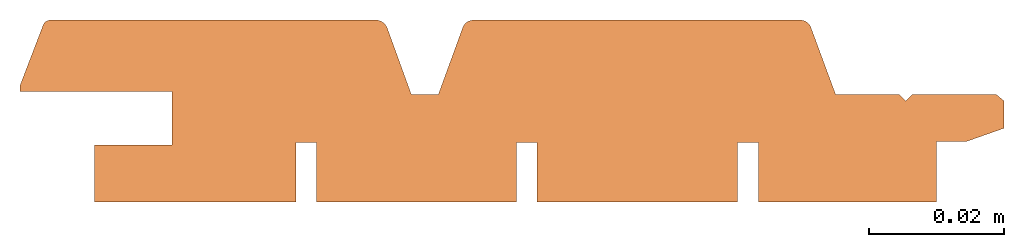
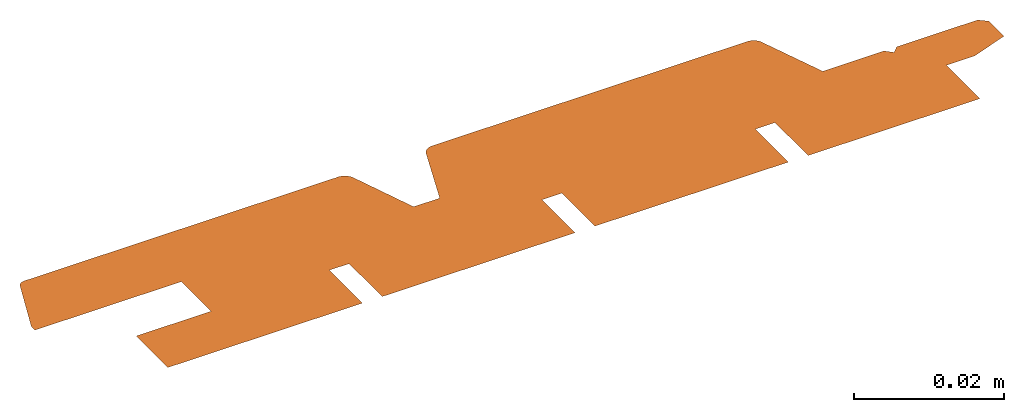
# One storey: 1 proxy.
"""IFC2X3 building model written with IfcOpenShell, lengths in millimetres."""

from ifc_helpers import new_model, entity, si_unit, converted_unit, direction, origin, origin_with_axes, place, context, project, spatial, faceted_brep, element, save


model = new_model("IFC2X3")

# Units and contexts
model_context = context("Model", 3, precision=1e-05, world=origin(), true_north=direction((0.0, 1.0, 0.0)))
ifc_project = project(units=[si_unit("LENGTHUNIT", "METRE", prefix="MILLI"), si_unit("AREAUNIT", "SQUARE_METRE"), si_unit("VOLUMEUNIT", "CUBIC_METRE"), converted_unit("PLANEANGLEUNIT", "DEGREE", entity("IfcPlaneAngleMeasure", 0.01745), si_unit("PLANEANGLEUNIT", "RADIAN"), dimensions=[0, 0, 0, 0, 0, 0, 0]), si_unit("SOLIDANGLEUNIT", "STERADIAN"), si_unit("MASSUNIT", "GRAM"), si_unit("TIMEUNIT", "SECOND"), si_unit("THERMODYNAMICTEMPERATUREUNIT", "DEGREE_CELSIUS"), si_unit("LUMINOUSINTENSITYUNIT", "LUMEN")], contexts=[model_context])

# Site, building, storey
site_placement = place(None, origin_with_axes())
site = spatial("IfcSite", under=ifc_project, at=site_placement, CompositionType="ELEMENT")
building_placement = place(site_placement, origin_with_axes())
building = spatial("IfcBuilding", under=site, at=building_placement, Name="Default Building", CompositionType="ELEMENT")
storey_placement = place(building_placement, origin_with_axes())
storey = spatial("IfcBuildingStorey", under=building, at=storey_placement, Name="Default Building Storey", CompositionType="ELEMENT", Elevation=0.0)

# Proxy
proxy_placement = place(storey_placement, origin_with_axes())
element("IfcBuildingElementProxy", 1, at=proxy_placement, inside=storey, context=model_context, shape_type="Brep", body=[
    faceted_brep([(146.0260360718993, 15.01647765539897, 0.0), (144.8649542495361, 15.98359231811794, 0.0), (132.3971930993436, 15.98359231811794, 0.0), (131.4621651584728, 15.01798283643557, 0.0), (130.4649739191964, 15.98359231811794, 0.0), (121.0371753122938, 15.98359231811794, 0.0), (117.3701394846128, 25.92051490603937, 0.0), (117.3035940643231, 26.07606441742268, 0.0), (117.2216389733124, 26.22407558764477, 0.0), (117.1251167969576, 26.36302670467824, 0.0), (117.0150198857447, 26.49148920346479, 0.0), (116.8924801528511, 26.60814235308131, 0.0), (116.7587574368761, 26.71178683525649, 0.0), (116.6152265493621, 26.80135707463636, 0.0), (116.4633631402721, 26.8759321940306, 0.0), (116.3047285267404, 26.93474548200818, 0.0), (116.1409536410743, 26.97719227550516, 0.0), (115.9737222630382, 27.00283617640313, 0.0), (115.804753708809, 27.01141353816535, 0.0), (67.31276641968357, 27.01141353816535, 0.0), (67.13845087135603, 27.00253934970534, 0.0), (66.96593774741318, 26.97600854351622, 0.0), (66.79701083515492, 26.93209544837979, 0.0), (66.63341684041916, 26.87125412610663, 0.0), (66.47684732662701, 26.79411367653268, 0.0), (66.32892122400177, 26.70147173262129, 0.0), (66.19116808981522, 26.5942862129308, 0.0), (66.06501229275091, 26.47366541672787, 0.0), (65.95175828491932, 26.34085656416277, 0.0), (65.85257711381088, 26.19723290000147, 0.0), (65.76849431365362, 26.04427949426208, 0.0), (65.70037930138027, 25.88357788657703, 0.0), (62.08615409441679, 15.98359231811794, 0.0), (58.0727653265676, 15.98359231811794, 0.0), (54.44787599820436, 25.97757676331268, 0.0), (54.34823802204339, 26.14840350365386, 0.0), (54.23173914749844, 26.30820811478519, 0.0), (54.09958809849606, 26.45533255788234, 0.0), (53.95315599673535, 26.58825035609985, 0.0), (53.79396213573423, 26.70558243239895, 0.0), (53.62365821753259, 26.80611141804118, 0.0), (53.44401121560101, 26.88879428329162, 0.0), (53.25688504176118, 26.95277315928328, 0.0), (53.064221207332, 26.99738423876062, 0.0), (52.86801867914743, 27.02216466335388, 0.0), (52.67031313944987, 27.02685732592607, 0.0), (52.47315586484742, 27.01141353816537, 0.0), (4.565231539202856, 27.01141353816535, 0.0), (4.44455799075367, 27.00937934962371, 0.0), (4.324737611836052, 26.99491145363362, 0.0), (4.207048089330539, 26.96816412646307, 0.0), (4.092744388045624, 26.92942258427759, 0.0), (3.983045368586237, 26.87909994177953, 0.0), (3.879120790213978, 26.81773280702085, 0.0), (3.782078837292436, 26.74597555936236, 0.0), (3.692954302327063, 26.66459337159661, 0.0), (3.61269755160857, 26.57445405064038, 0.0), (3.542164391122498, 26.47651878380461, 0.0), (3.48210694078874, 26.37183188931566, 0.0), (3.433165614342109, 26.26150968038206, 0.0), (0.0, 17.30075674278882, 0.0), (0.0, 16.39548108086797, 0.0), (22.53059272150378, 16.39548108086797, 0.0), (22.53059272150378, 8.459231111361609, 0.0), (11.03359181510871, 8.459231111361609, 0.0), (11.03359181510871, 0.00999160010009259, 0.0), (40.95150253301925, 0.0009252788266565837, 0.0), (40.95150253301925, 8.834893182928129, 0.0), (44.00482575972281, 8.834893182928129, 0.0), (44.00482575972281, 0.0, 0.0), (73.68435552531251, 0.0009252788266565837, 0.0), (73.68435552531251, 8.834893182928129, 0.0), (76.73767875201618, 8.834893182928129, 0.0), (76.73767875201618, 0.0, 0.0), (106.5056999638953, 0.0009252788266565837, 0.0), (106.5056999638953, 8.834893182928129, 0.0), (109.5590231905987, 8.834893182928129, 0.0), (109.5590231905987, 0.0, 0.0), (135.9945617870457, 0.0, 0.0), (135.9945617870457, 8.965073818014746, 0.0), (140.3509756328737, 8.965073818014746, 0.0), (146.0260360718993, 10.95738021059701, 0.0)], [[[0, 1, 2, 3, 4, 5, 6, 7, 8, 9, 10, 11, 12, 13, 14, 15, 16, 17, 18, 19, 20, 21, 22, 23, 24, 25, 26, 27, 28, 29, 30, 31, 32, 33, 34, 35, 36, 37, 38, 39, 40, 41, 42, 43, 44, 45, 46, 47, 48, 49, 50, 51, 52, 53, 54, 55, 56, 57, 58, 59, 60, 61, 62, 63, 64, 65, 66, 67, 68, 69, 70, 71, 72, 73, 74, 75, 76, 77, 78, 79, 80, 81]]]),
])

save(model, "model.ifc")
